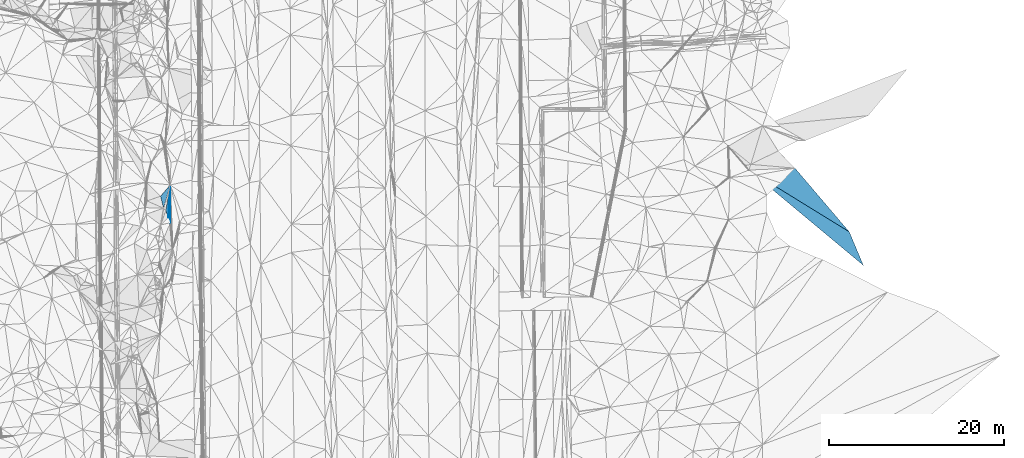
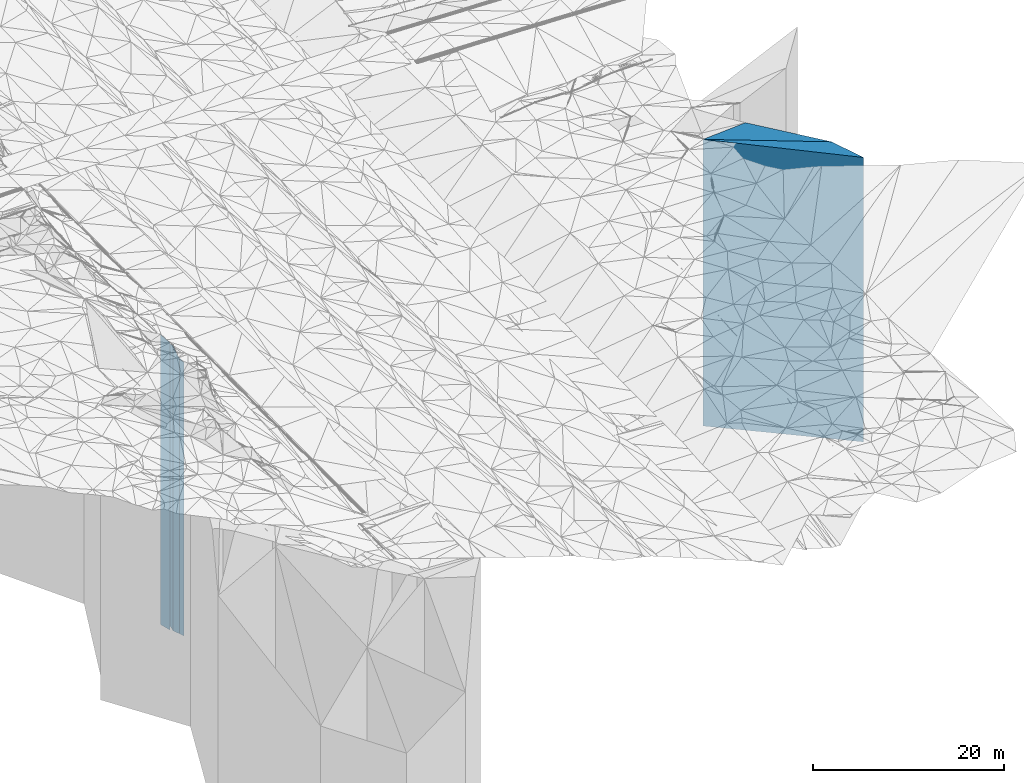
# One storey, part 201 of 275: 5 plates.
"""IFC2X3 building model written with IfcOpenShell, lengths in millimetres."""

from ifc_helpers import new_model, si_unit, frame, origin_with_axes, place, context, subcontext, project, spatial, faceted_brep, material, type_object, element, save


model = new_model("IFC2X3")

# Units and contexts
model_context = context("Model", 3, precision=1e-05, world=origin_with_axes())
body_context = subcontext(model_context, "Body", "Model", "MODEL_VIEW")
ifc_project = project(units=[si_unit("LENGTHUNIT", "METRE", prefix="MILLI"), si_unit("AREAUNIT", "SQUARE_METRE"), si_unit("VOLUMEUNIT", "CUBIC_METRE"), si_unit("MASSUNIT", "GRAM", prefix="KILO"), si_unit("TIMEUNIT", "SECOND"), si_unit("PLANEANGLEUNIT", "RADIAN"), si_unit("SOLIDANGLEUNIT", "STERADIAN"), si_unit("THERMODYNAMICTEMPERATUREUNIT", "DEGREE_CELSIUS"), si_unit("LUMINOUSINTENSITYUNIT", "LUMEN")], contexts=[model_context])

# Site, building, storey
site_placement = place(None, origin_with_axes())
site = spatial("IfcSite", under=ifc_project, at=site_placement, CompositionType="ELEMENT")
building_placement = place(site_placement, origin_with_axes())
building = spatial("IfcBuilding", under=site, at=building_placement, Name="Undefined", CompositionType="ELEMENT")
storey_placement = place(building_placement, origin_with_axes())
storey = spatial("IfcBuildingStorey", under=building, at=storey_placement, Name="Undefined", CompositionType="ELEMENT", Elevation=0.0)

# Plates
ifc_material = material()
plate_type_1 = type_object("IfcPlateType", PredefinedType="NOTDEFINED")
plate_1_placement = place(storey_placement, frame((-98004.2512851818, 33662.7914771034, 25349.0), z_axis=(0.93200320198404, 0.362450039993786, 0.0), x_axis=(0.362450039993793, -0.932003201984037, 0.0)))
element("IfcPlate", 1, at=plate_1_placement, inside=storey, type_object=plate_type_1, material=ifc_material, Name="00", context=body_context, shape_type="Brep", body=[
    faceted_brep([(0.0, -18911.0, 1.45519152283669e-11), (-2527.25415039063, -17637.0, 1555.84814453128), (-2527.25415039063, 17521.0, 1555.84814453128), (0.0, 17521.0, 1.45519152283669e-11), (880.908630371094, -17521.0, 1.44063960760832e-09), (880.908630371094, 17521.0, 1.44063960760832e-09)], [[[0, 1, 2, 3]], [[1, 4, 5, 2]], [[4, 0, 3, 5]], [[5, 3, 2]], [[4, 1, 0]]]),
])
plate_type_2 = type_object("IfcPlateType", PredefinedType="NOTDEFINED")
plate_2_placement = place(storey_placement, frame((-97684.9659202173, 32841.7818208146, 25274.0), z_axis=(0.933344150937659, 0.358982862976021, 0.0), x_axis=(0.358982862976016, -0.933344150937661, 0.0)))
element("IfcPlate", 2, at=plate_2_placement, inside=storey, type_object=plate_type_2, material=ifc_material, Name="00", context=body_context, shape_type="Brep", body=[
    faceted_brep([(0.0, -17596.0, -1.45519152283669e-11), (-3413.92309570313, -17712.0, 1543.16772460936), (-3413.92309570313, 17446.0, 1543.16772460936), (-1.45519152283669e-11, 17446.0, 7.27595761418343e-12), (610.737243652344, -17446.0, -2.4156179279089e-09), (610.737243652344, 17446.0, -2.4156179279089e-09)], [[[0, 1, 2, 3]], [[1, 4, 5, 2]], [[4, 0, 3, 5]], [[5, 3, 2]], [[4, 1, 0]]]),
])
plate_type_3 = type_object("IfcPlateType", PredefinedType="NOTDEFINED")
plate_3_placement = place(storey_placement, frame((-18249.3435653095, 27392.822370747, 25988.0), z_axis=(-0.921618406972387, -0.388097296988371, 0.0), x_axis=(-0.388097296988372, 0.921618406972387, 0.0)))
element("IfcPlate", 3, at=plate_3_placement, inside=storey, type_object=plate_type_3, material=ifc_material, Name="00", context=body_context, shape_type="Brep", body=[
    faceted_brep([(0.0, -18160.0, 0.0), (15124.5185546875, -18443.0, 7822.71582031251), (15124.5185546875, 18160.0, 7822.71582031251), (0.0, 18160.0, 0.0), (4168.65673828125, -18400.0, -3.64889274351299e-09), (4168.65673828125, 18160.0, -3.64889274351299e-09)], [[[0, 1, 2, 3]], [[1, 4, 5, 2]], [[4, 0, 3, 5]], [[5, 3, 2]], [[4, 1, 0]]]),
])
plate_type_4 = type_object("IfcPlateType", PredefinedType="NOTDEFINED")
plate_4_placement = place(storey_placement, frame((-98566.6692560539, 35305.6810126596, 25407.0), z_axis=(0.970054191166219, 0.24288858804162, 0.0), x_axis=(0.242888588041624, -0.970054191166218, 0.0)))
element("IfcPlate", 4, at=plate_4_placement, inside=storey, type_object=plate_type_4, material=ifc_material, Name="00", context=body_context, shape_type="Brep", body=[
    faceted_brep([(7.27595761418343e-12, -19483.0, 1.45519152283669e-11), (-971.892700195313, -17579.0, 1373.66723632814), (-971.892700195313, 17579.0, 1373.66723632814), (1.45519152283669e-11, 17579.0, 0.0), (1410.56726074219, -19123.0, 6.34463503956795e-09), (1410.56726074219, 17579.0, 6.34463503956795e-09)], [[[0, 1, 2, 3]], [[1, 4, 5, 2]], [[4, 0, 3, 5]], [[5, 3, 2]], [[4, 1, 0]]]),
])
plate_type_5 = type_object("IfcPlateType", PredefinedType="NOTDEFINED")
plate_5_placement = place(storey_placement, frame((-26071.612804101, 38513.4027942616, 26108.0), z_axis=(0.041341448993824, -0.99914507685075, 0.0), x_axis=(-0.99914507685075, -0.0413414489938243, 0.0)))
element("IfcPlate", 5, at=plate_5_placement, inside=storey, type_object=plate_type_5, material=ifc_material, Name="00", context=body_context, shape_type="Brep", body=[
    faceted_brep([(7.27595761418343e-12, -18481.0, -1.45519152283669e-11), (-5898.2099609375, -18280.0, 7528.94677734374), (-5898.2099609375, 18280.0, 7528.94677734374), (7.27595761418343e-12, 18280.0, -1.45519152283669e-11), (5261.57226562501, -18323.0, -3.63070284947753e-09), (5261.57226562501, 18280.0, -3.63070284947753e-09)], [[[0, 1, 2, 3]], [[1, 4, 5, 2]], [[4, 0, 3, 5]], [[5, 3, 2]], [[4, 1, 0]]]),
])

save(model, "model.ifc")
